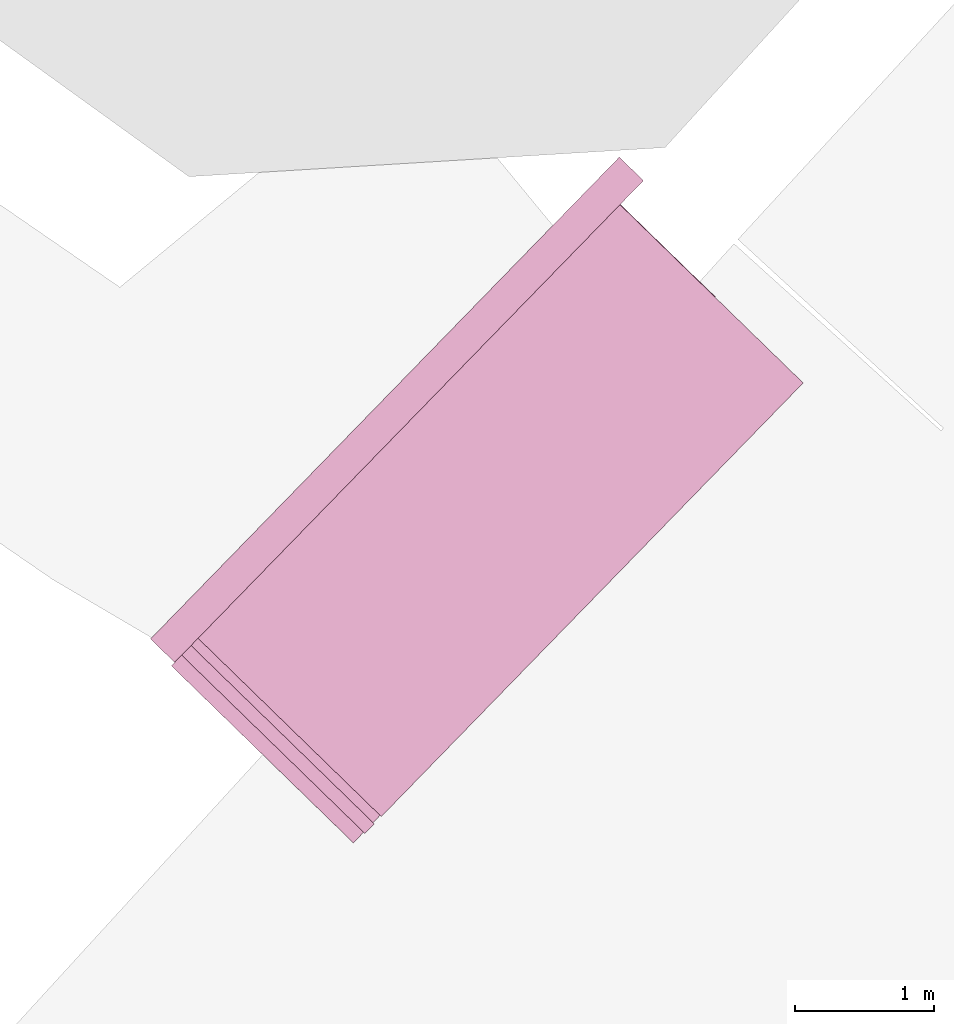
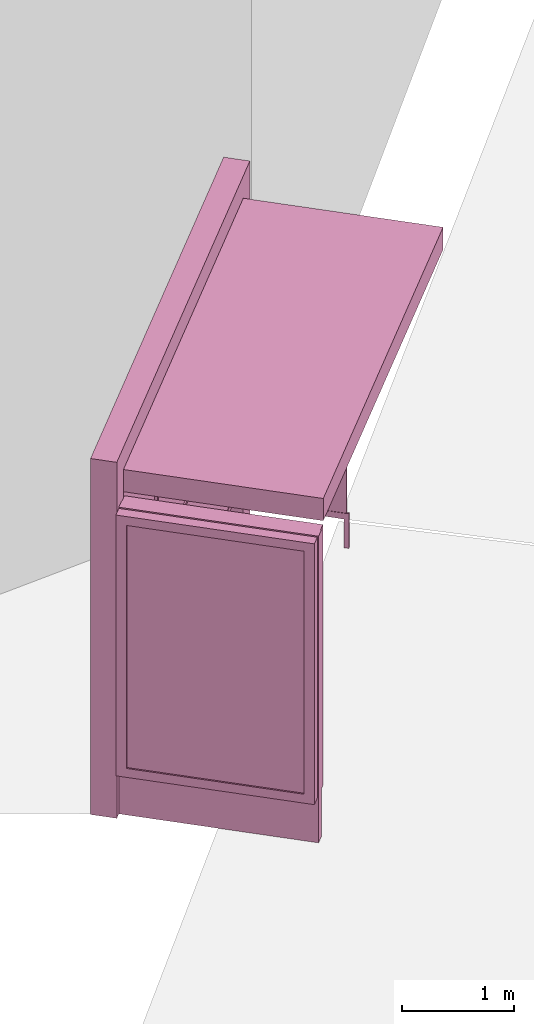
# One storey, part 16 of 200: 1 furnishing.
"""IFC4 building model written with IfcOpenShell, lengths in metres."""

from ifc_helpers import new_model, si_unit, origin_with_axes, place, context, subcontext, project, spatial, triangles, material, element, save


model = new_model("IFC4")

# Units and contexts
model_context = context("Model", 3, precision=1e-05, world=origin_with_axes())
body_context = subcontext(model_context, "Body", "Model", "MODEL_VIEW")
ifc_project = project(units=[si_unit("VOLUMEUNIT", "CUBIC_METRE"), si_unit("LENGTHUNIT", "METRE"), si_unit("AREAUNIT", "SQUARE_METRE")], contexts=[model_context])

# Site, building, storey
site_placement = place(None, origin_with_axes())
site = spatial("IfcSite", under=ifc_project, at=site_placement)
building_placement = place(site_placement, origin_with_axes())
building = spatial("IfcBuilding", under=site, at=building_placement, Name="Building")
storey_placement = place(building_placement, origin_with_axes())
storey = spatial("IfcBuildingStorey", under=building, at=storey_placement, Name="Ground")

# Furnishing
ifc_material = material(Name="busStop")
furnishing_placement = place(storey_placement, origin_with_axes())
element("IfcFurnishingElement", 1, at=furnishing_placement, inside=storey, material=ifc_material, Name="cw_instances_busStop_30", context=body_context, shape_type="Tessellation", body=[
    triangles([(510.81362514484823, -674.8429660042176, 3.3826375611235573), (512.3524115646801, -670.2866190238973, 3.3826375611235573), (509.3267755446598, -673.3962991293622, 3.3826375611235573), (513.8392614378605, -671.7332859177407, 3.3826375611235573), (510.81362521395226, -674.8429660714539, 3.6236783199298275), (512.3524116337842, -670.2866190911336, 3.6236783199298275), (513.8392615069646, -671.733285984977, 3.6236783199298275), (509.32677561376386, -673.3962991965985, 3.6236783199298275), (510.81362514484823, -674.8429660042176, 3.3826375611235573), (513.8392615069646, -671.733285984977, 3.6236783199298275), (513.8392614378605, -671.7332859177407, 3.3826375611235573), (510.81362521395226, -674.8429660714539, 3.6236783199298275), (513.8392614378605, -671.7332859177407, 3.3826375611235573), (512.3524116337842, -670.2866190911336, 3.6236783199298275), (512.3524115646801, -670.2866190238973, 3.3826375611235573), (513.8392615069646, -671.733285984977, 3.6236783199298275), (512.3524115646801, -670.2866190238973, 3.3826375611235573), (509.32677561376386, -673.3962991965985, 3.6236783199298275), (509.3267755446598, -673.3962991293622, 3.3826375611235573), (512.3524116337842, -670.2866190911336, 3.6236783199298275), (509.3267755446598, -673.3962991293622, 3.3826375611235573), (510.81362521395226, -674.8429660714539, 3.6236783199298275), (510.81362514484823, -674.8429660042176, 3.3826375611235573), (509.32677561376386, -673.3962991965985, 3.6236783199298275), (509.499535902697, -673.5643902885336, 3.864718677001767), (509.15868490999424, -673.5690596165804, 3.864718677001767), (509.3267758786626, -673.3962994543378, 3.864718677001767), (509.3314449340287, -673.737150450776, 3.864718677001767), (509.499535902697, -673.5643902885336, 3.6236783199298275), (509.3314449340287, -673.737150450776, 3.864718677001767), (509.499535902697, -673.5643902885336, 3.864718677001767), (509.3314449340287, -673.737150450776, 3.6236783199298275), (512.6932628954323, -670.2819503162302, 3.6236783199298275), (512.5205027331898, -670.1138593475619, 3.864718677001767), (512.5205027331898, -670.1138593475619, 3.6236783199298275), (512.6932628954323, -670.2819503162302, 3.864718677001767), (512.3524119102002, -670.2866193600789, 3.6236783199298275), (512.5205027331898, -670.1138593475619, 3.864718677001767), (512.3524119102002, -670.2866193600789, 3.864718677001767), (512.5205027331898, -670.1138593475619, 3.6236783199298275), (509.15868478330356, -673.5690594933137, 3.6236783199298275), (509.3314449340287, -673.737150450776, 3.864718677001767), (509.3314449340287, -673.737150450776, 3.6236783199298275), (509.15868490999424, -673.5690596165804, 3.864718677001767), (512.5251719342347, -670.4547101942746, 3.864718677001767), (512.3524119102002, -670.2866193600789, 3.864718677001767), (512.5251719342347, -670.4547101942746, 3.6236783199298275), (512.5251719342347, -670.4547101942746, 3.864718677001767), (509.15868478330356, -673.5690594933137, 3.6236783199298275), (509.3267758786626, -673.3962994543378, 3.864718677001767), (509.15868490999424, -673.5690596165804, 3.864718677001767), (509.3267758786626, -673.3962994543378, 3.6236783199298275), (512.6932628954323, -670.2819503162302, 3.864718677001767), (512.5205027331898, -670.1138593475619, 3.864718677001767), (512.6932628954323, -670.2819503162302, 3.6236783199298275), (512.6932628954323, -670.2819503162302, 3.864718677001767), (509.1586841613674, -673.5690588881866, 9.480930192426488e-07), (509.3314441162978, -673.7371496551459, 8.998848996201414e-07), (509.32677513003574, -673.3962987259441, 9.480930192426488e-07), (509.1586841613674, -673.5690588881866, 9.480930192426488e-07), (509.3267758786626, -673.3962994543378, 3.6236783199298275), (509.49953521165685, -673.5643896161702, 8.998848996201414e-07), (509.499535902697, -673.5643902885336, 3.6236783199298275), (509.32677513003574, -673.3962987259441, 9.480930192426488e-07), (509.3314441162978, -673.7371496551459, 8.998848996201414e-07), (509.49953521165685, -673.5643896161702, 8.998848996201414e-07), (512.6932610016087, -670.2819506035411, 8.998848996201414e-07), (512.520501984563, -670.1138586191681, 9.480930192426488e-07), (512.525170167413, -670.4547106275755, 8.998848996201414e-07), (512.6932610016087, -670.2819506035411, 8.998848996201414e-07), (512.5251719342347, -670.4547101942746, 3.6236783199298275), (512.3524100857919, -670.2866197373495, 9.480930192426488e-07), (512.3524119102002, -670.2866193600789, 3.6236783199298275), (512.525170167413, -670.4547106275755, 8.998848996201414e-07), (512.520501984563, -670.1138586191681, 9.480930192426488e-07), (512.3524100857919, -670.2866197373495, 9.480930192426488e-07), (513.2068975161724, -671.1183603637644, 0.3459945917589383), (512.4570075507662, -670.3887376947206, 3.3826375611235573), (512.45700692883, -670.3887370895935, 0.34599476852204364), (513.2068980805219, -671.1183609128612, 3.3826375611235573), (512.4458008829289, -670.4002544145474, 0.34599476852204364), (513.1956920346207, -671.1298782378152, 3.3826375611235573), (513.1956914702713, -671.1298776887184, 0.3459945917589383), (512.445801504865, -670.4002550196745, 3.3826375611235573), (513.1956914702713, -671.1298776887184, 0.3459945917589383), (513.2068980805219, -671.1183609128612, 3.3826375611235573), (513.2068975161724, -671.1183603637644, 0.3459945917589383), (513.1956920346207, -671.1298782378152, 3.3826375611235573), (512.4429993014157, -670.4031338177692, 0.313856054245785), (513.2096989286608, -671.1154810651325, 0.3138558614133065), (512.4598083758705, -670.3858578245797, 0.313856054245785), (513.1928898542061, -671.132757058322, 0.3138558614133065), (512.4429993014157, -670.4031338177692, 0.37813349886767544), (513.2096989401782, -671.1154810763385, 0.37813330603519696), (513.1928898657235, -671.1327570695281, 0.37813330603519696), (512.4598083758705, -670.3858578245797, 0.37813349886767544), (512.4429993014157, -670.4031338177692, 0.313856054245785), (513.1928898657235, -671.1327570695281, 0.37813330603519696), (513.1928898542061, -671.132757058322, 0.3138558614133065), (512.4429993014157, -670.4031338177692, 0.37813349886767544), (513.2096989286608, -671.1154810651325, 0.3138558614133065), (512.4598083758705, -670.3858578245797, 0.37813349886767544), (512.4598083758705, -670.3858578245797, 0.313856054245785), (513.2096989401782, -671.1154810763385, 0.37813330603519696), (513.2096989401782, -671.1154810763385, 0.37813330603519696), (513.1928898542061, -671.132757058322, 0.3138558614133065), (513.1928898657235, -671.1327570695281, 0.37813330603519696), (513.2096989286608, -671.1154810651325, 0.3138558614133065), (513.2113513548538, -671.145513642766, 0.37813330603519696), (513.1912363441384, -671.1027258251041, 0.37813330603519696), (513.2229552269883, -671.13358744085, 0.37813330603519696), (513.1796324720038, -671.1146520270202, 0.37813330603519696), (513.2113511705764, -671.1455134634691, 1.446243588675227e-07), (513.2229552269883, -671.13358744085, 0.37813330603519696), (513.222955042711, -671.1335872615531, 1.446243588675227e-07), (513.2113513548538, -671.145513642766, 0.37813330603519696), (513.222955042711, -671.1335872615531, 1.446243588675227e-07), (513.1912363441384, -671.1027258251041, 0.37813330603519696), (513.191236263517, -671.1027257466617, 1.6069373207502523e-07), (513.2229552269883, -671.13358744085, 0.37813330603519696), (513.191236263517, -671.1027257466617, 1.6069373207502523e-07), (513.1796324720038, -671.1146520270202, 0.37813330603519696), (513.1796323913825, -671.1146519485777, 1.6069373207502523e-07), (513.1912363441384, -671.1027258251041, 0.37813330603519696), (513.1796323913825, -671.1146519485777, 1.6069373207502523e-07), (513.2113513548538, -671.145513642766, 0.37813330603519696), (513.2113511705764, -671.1455134634691, 1.446243588675227e-07), (513.1796324720038, -671.1146520270202, 0.37813330603519696), (510.4578625741271, -672.673845460023, 1.1248564780513874), (511.46849650632066, -671.4151122446012, 1.1248565744676267), (511.57846863036565, -671.5221121490774, 1.1248564780513874), (510.34789058829017, -672.5668456900196, 1.1248565744676267), (511.57846849215764, -671.5221120146048, 4.981505694325782e-07), (510.4578625741271, -672.673845460023, 0.964162810253855), (511.57846863036565, -671.5221121490774, 0.964162810253855), (510.457862332263, -672.6738452246958, 4.981505694325782e-07), (511.4684962299046, -671.4151119756559, 5.302893158475833e-07), (511.57846863036565, -671.5221121490774, 0.964162810253855), (511.46849650632066, -671.4151122446012, 0.9641629066700942), (511.57846849215764, -671.5221120146048, 4.981505694325782e-07), (510.3478903118741, -672.5668454210742, 5.302893158475833e-07), (511.46849650632066, -671.4151122446012, 0.9641629066700942), (510.34789058829017, -672.5668456900196, 0.9641629066700942), (511.4684962299046, -671.4151119756559, 5.302893158475833e-07), (510.457862332263, -672.6738452246958, 4.981505694325782e-07), (510.34789058829017, -672.5668456900196, 0.9641629066700942), (510.4578625741271, -672.673845460023, 0.964162810253855), (510.3478903118741, -672.5668454210742, 5.302893158475833e-07), (512.0391620431473, -671.9703543885406, 1.124856381635148), (510.91855604449535, -673.1220877555165, 0.9641627138376155), (510.91855606753, -673.1220877779286, 1.124856381635148), (512.0391620316299, -671.9703543773346, 0.9641627138376155), (511.46849650632066, -671.4151122446012, 1.1248565744676267), (511.57846863036565, -671.5221121490774, 1.1248564780513874), (510.34789058829017, -672.5668456900196, 1.1248565744676267), (511.46849650632066, -671.4151122446012, 1.1248565744676267), (510.4578625741271, -672.673845460023, 1.1248564780513874), (510.34789058829017, -672.5668456900196, 1.1248565744676267), (510.91855606753, -673.1220877779286, 1.124856381635148), (512.0391620431473, -671.9703543885406, 1.124856381635148), (510.91855604449535, -673.1220877555165, 0.9641627138376155), (510.91855606753, -673.1220877779286, 1.124856381635148), (512.0391620431473, -671.9703543885406, 1.124856381635148), (512.0391620316299, -671.9703543773346, 0.9641627138376155), (509.3399022262601, -673.603948172838, 0.34599476852204364), (512.546986485765, -670.307781119873, 3.503157940526693), (512.5469858062422, -670.3077804587156, 0.34599476852204364), (509.3399027099882, -673.6039486434925, 3.503157940526693), (512.535468469771, -670.2965744016084, 0.34599476852204364), (509.3283853850343, -673.5927425975914, 3.503157940526693), (509.32838490130615, -673.592742126937, 0.34599476852204364), (512.5354691608111, -670.2965750739718, 3.503157940526693), (509.38815324049347, -673.8171253333096, 0.5810001600002933), (510.5552505307453, -674.9526794535547, 3.2193552137185355), (510.5552501161212, -674.9526790501366, 0.5809998707515756), (509.38815367815226, -673.8171257591398, 3.2193552137185355), (509.30784317576473, -673.7614063156204, 0.4845839046859049), (510.5440440702201, -674.9641963750905, 0.5809998707515756), (510.6131469553683, -675.0314337446442, 0.48458358329844076), (509.37694719459233, -673.8286426582636, 0.5810001600002933), (510.5440444848442, -674.9641967785086, 3.2193552137185355), (510.6131486418799, -675.0314332556244, 3.3157713565473115), (509.37694763225113, -673.8286430840938, 3.2193552137185355), (509.3078436479755, -673.7614067750687, 3.3157713565473115), (509.37694719459233, -673.8286426582636, 0.5810001600002933), (510.5552501161212, -674.9526790501366, 0.5809998707515756), (510.5440440702201, -674.9641963750905, 0.5809998707515756), (509.38815324049347, -673.8171253333096, 0.5810001600002933), (510.5440440702201, -674.9641963750905, 0.5809998707515756), (510.5552505307453, -674.9526794535547, 3.2193552137185355), (510.5440444848442, -674.9641967785086, 3.2193552137185355), (510.5552501161212, -674.9526790501366, 0.5809998707515756), (510.5440444848442, -674.9641967785086, 3.2193552137185355), (509.38815367815226, -673.8171257591398, 3.2193552137185355), (509.37694763225113, -673.8286430840938, 3.2193552137185355), (510.5552505307453, -674.9526794535547, 3.2193552137185355), (509.37694763225113, -673.8286430840938, 3.2193552137185355), (509.38815324049347, -673.8171253333096, 0.5810001600002933), (509.37694719459233, -673.8286426582636, 0.5810001600002933), (509.38815367815226, -673.8171257591398, 3.2193552137185355), (510.8284416298224, -674.8101599069057, 3.3157713565473115), (509.3078436479755, -673.7614067750687, 3.3157713565473115), (509.5231368432301, -673.540133628059, 3.3157713565473115), (510.6131486418799, -675.0314332556244, 3.3157713565473115), (510.8284410078862, -674.8101593017785, 0.48458358329844076), (510.6131486418799, -675.0314332556244, 3.3157713565473115), (510.8284416298224, -674.8101599069057, 3.3157713565473115), (510.6131469553683, -675.0314337446442, 0.48458358329844076), (509.30784317576473, -673.7614063156204, 0.4845839046859049), (509.5231368432301, -673.540133628059, 3.3157713565473115), (509.3078436479755, -673.7614067750687, 3.3157713565473115), (509.52313629039793, -673.5401330901683, 0.4845839046859049), (509.5810342402898, -673.6188867353533, 0.5810001600002933), (510.7481314268856, -674.7544407547438, 3.2193552137185355), (509.5810348161566, -673.6188872956561, 3.2193552137185355), (510.74813101226147, -674.7544403513258, 0.5809998707515756), (509.52313629039793, -673.5401330901683, 0.4845839046859049), (510.7593370581626, -674.7429230263718, 0.5809998707515756), (509.59224028619093, -673.6073694103993, 0.5810001600002933), (510.8284410078862, -674.8101593017785, 0.48458358329844076), (510.75933747278674, -674.7429234297898, 3.2193552137185355), (510.8284416298224, -674.8101599069057, 3.3157713565473115), (509.59224086205774, -673.6073699707022, 3.2193552137185355), (509.5231368432301, -673.540133628059, 3.3157713565473115), (509.59224028619093, -673.6073694103993, 0.5810001600002933), (510.74813101226147, -674.7544403513258, 0.5809998707515756), (509.5810342402898, -673.6188867353533, 0.5810001600002933), (510.7593370581626, -674.7429230263718, 0.5809998707515756), (510.7593370581626, -674.7429230263718, 0.5809998707515756), (510.7481314268856, -674.7544407547438, 3.2193552137185355), (510.74813101226147, -674.7544403513258, 0.5809998707515756), (510.75933747278674, -674.7429234297898, 3.2193552137185355), (510.75933747278674, -674.7429234297898, 3.2193552137185355), (509.5810348161566, -673.6188872956561, 3.2193552137185355), (510.7481314268856, -674.7544407547438, 3.2193552137185355), (509.59224086205774, -673.6073699707022, 3.2193552137185355), (509.59224086205774, -673.6073699707022, 3.2193552137185355), (509.5810342402898, -673.6188867353533, 0.5810001600002933), (509.5810348161566, -673.6188872956561, 3.2193552137185355), (509.59224028619093, -673.6073694103993, 0.5810001600002933), (510.6959627218588, -674.9638968278457, 3.3287619342644956), (509.44910827965015, -673.6162181258476, 3.3287619342644956), (510.76319793269016, -674.894793972269, 3.3287619342644956), (509.3818720042434, -673.6853220755712, 3.3287619342644956), (510.69596103908253, -674.9638975895463, 0.0), (510.76319793269016, -674.894793972269, 3.3287619342644956), (510.763197448962, -674.8947935016146, 0.0), (510.6959627218588, -674.9638968278457, 3.3287619342644956), (510.763197448962, -674.8947935016146, 0.0), (509.44910827965015, -673.6162181258476, 3.3287619342644956), (509.44910773833533, -673.616217599163, 5.142199426400808e-07), (510.76319793269016, -674.894793972269, 3.3287619342644956), (509.44910773833533, -673.616217599163, 5.142199426400808e-07), (509.3818720042434, -673.6853220755712, 3.3287619342644956), (509.3818714629286, -673.6853215488866, 5.142199426400808e-07), (509.44910827965015, -673.6162181258476, 3.3287619342644956), (509.3818714629286, -673.6853215488866, 5.142199426400808e-07), (510.6959627218588, -674.9638968278457, 3.3287619342644956), (510.69596103908253, -674.9638975895463, 0.0), (509.3818720042434, -673.6853220755712, 3.3287619342644956), (509.34278156037794, -673.6067496871149, 0.313856054245785), (512.4632023266827, -670.3650869924458, 0.313856054245785), (509.32550549808434, -673.5899405454238, 0.313856054245785), (512.4804783083549, -670.3818960556945, 0.313856054245785), (509.34278156037794, -673.6067496871149, 0.37813349886767544), (512.4632023266827, -670.3650869924458, 0.37813349886767544), (512.4804783083549, -670.3818960556945, 0.37813349886767544), (509.32550549808434, -673.5899405454238, 0.37813349886767544), (509.34278156037794, -673.6067496871149, 0.313856054245785), (512.4804783083549, -670.3818960556945, 0.37813349886767544), (512.4804783083549, -670.3818960556945, 0.313856054245785), (509.34278156037794, -673.6067496871149, 0.37813349886767544), (512.4632023266827, -670.3650869924458, 0.313856054245785), (509.32550549808434, -673.5899405454238, 0.37813349886767544), (509.32550549808434, -673.5899405454238, 0.313856054245785), (512.4632023266827, -670.3650869924458, 0.37813349886767544), (510.46060386051613, -672.4523067132734, 1.5290613779533648), (511.3570889240251, -671.5309202547086, 2.8146110577904615), (510.4606041369322, -672.4523069822188, 2.8146110577904615), (511.35708864760903, -671.5309199857633, 1.5290613779533648), (510.49269703283284, -672.4386914257938, 1.5612002850621018), (511.3443578339836, -671.5633743249426, 2.7824723435142027), (511.34435743087687, -671.5633739327307, 1.5612002850621018), (510.4926971710409, -672.4386915602664, 2.7824723435142027), (510.46060386051613, -672.4523067132734, 1.5290613779533648), (511.37828701945926, -671.5515454286445, 1.5290613779533648), (511.35708864760903, -671.5309199857633, 1.5290613779533648), (510.48180209415835, -672.472932021682, 1.5290613779533648), (511.35708864760903, -671.5309199857633, 1.5290613779533648), (511.37828714614994, -671.5515455519112, 2.8146110577904615), (511.3570889240251, -671.5309202547086, 2.8146110577904615), (511.37828701945926, -671.5515454286445, 1.5290613779533648), (511.3570889240251, -671.5309202547086, 2.8146110577904615), (510.4818023705744, -672.4729322906275, 2.8146110577904615), (510.4606041369322, -672.4523069822188, 2.8146110577904615), (511.37828714614994, -671.5515455519112, 2.8146110577904615), (510.4606041369322, -672.4523069822188, 2.8146110577904615), (510.48180209415835, -672.472932021682, 1.5290613779533648), (510.46060386051613, -672.4523067132734, 1.5290613779533648), (510.4818023705744, -672.4729322906275, 2.8146110577904615), (511.61879760594996, -671.261941334135, 1.5290613779533648), (512.1791010813777, -670.6860749793581, 2.8146110577904615), (511.61879808781043, -671.2619416684491, 2.8146110577904615), (512.1791008049616, -670.6860747104128, 1.5290613779533648), (511.65089074091316, -671.2483258085266, 1.5612002850621018), (512.1663698176424, -670.7185288133311, 2.7824723435142027), (512.1663696103303, -670.7185286116221, 1.5612002850621018), (511.65089114401997, -671.2483262007387, 2.7824723435142027), (511.61879760594996, -671.261941334135, 1.5290613779533648), (512.2002990270865, -670.7067000076154, 1.5290613779533648), (512.1791008049616, -670.6860747104128, 1.5290613779533648), (511.6399959778002, -671.2825667770163, 1.5290613779533648), (512.1791008049616, -670.6860747104128, 1.5290613779533648), (512.2002993035026, -670.7067002765607, 2.8146110577904615), (512.1791010813777, -670.6860749793581, 2.8146110577904615), (512.2002990270865, -670.7067000076154, 1.5290613779533648), (512.1791010813777, -670.6860749793581, 2.8146110577904615), (511.63999630993527, -671.2825669656517, 2.8146110577904615), (511.61879808781043, -671.2619416684491, 2.8146110577904615), (512.2002993035026, -670.7067002765607, 2.8146110577904615), (511.61879808781043, -671.2619416684491, 2.8146110577904615), (511.6399959778002, -671.2825667770163, 1.5290613779533648), (511.61879760594996, -671.261941334135, 1.5290613779533648), (511.63999630993527, -671.2825669656517, 2.8146110577904615), (510.48180209415835, -672.472932021682, 1.5290613779533648), (511.3558748249348, -671.5745800458681, 1.5612002850621018), (511.37828701945926, -671.5515454286445, 1.5290613779533648), (510.5042142195788, -672.4498973372222, 1.5612002850621018), (511.3558750207295, -671.574580236371, 2.7824723435142027), (511.37828714614994, -671.5515455519112, 2.8146110577904615), (510.50421449599486, -672.4498976061675, 2.7824723435142027), (510.4818023705744, -672.4729322906275, 2.8146110577904615), (511.6399959778002, -671.2825667770163, 1.5290613779533648), (512.1778869352843, -670.7297346575232, 1.5612002850621018), (512.2002990270865, -670.7067000076154, 1.5290613779533648), (511.6624082040752, -671.2595319889004, 1.5612002850621018), (512.1778872117003, -670.7297349264686, 2.7824723435142027), (512.2002993035026, -670.7067002765607, 2.8146110577904615), (511.66240846897387, -671.2595322466398, 2.7824723435142027), (511.63999630993527, -671.2825669656517, 2.8146110577904615), (510.5042142195788, -672.4498973372222, 1.5612002850621018), (511.34435743087687, -671.5633739327307, 1.5612002850621018), (511.3558748249348, -671.5745800458681, 1.5612002850621018), (510.49269703283284, -672.4386914257938, 1.5612002850621018), (511.3558748249348, -671.5745800458681, 1.5612002850621018), (511.3443578339836, -671.5633743249426, 2.7824723435142027), (511.3558750207295, -671.574580236371, 2.7824723435142027), (511.34435743087687, -671.5633739327307, 1.5612002850621018), (511.3558750207295, -671.574580236371, 2.7824723435142027), (510.4926971710409, -672.4386915602664, 2.7824723435142027), (510.50421449599486, -672.4498976061675, 2.7824723435142027), (511.3443578339836, -671.5633743249426, 2.7824723435142027), (510.50421449599486, -672.4498976061675, 2.7824723435142027), (510.49269703283284, -672.4386914257938, 1.5612002850621018), (510.5042142195788, -672.4498973372222, 1.5612002850621018), (510.4926971710409, -672.4386915602664, 2.7824723435142027), (511.6624082040752, -671.2595319889004, 1.5612002850621018), (512.1663696103303, -670.7185286116221, 1.5612002850621018), (512.1778869352843, -670.7297346575232, 1.5612002850621018), (511.65089074091316, -671.2483258085266, 1.5612002850621018), (512.1778869352843, -670.7297346575232, 1.5612002850621018), (512.1663698176424, -670.7185288133311, 2.7824723435142027), (512.1778872117003, -670.7297349264686, 2.7824723435142027), (512.1663696103303, -670.7185286116221, 1.5612002850621018), (512.1778872117003, -670.7297349264686, 2.7824723435142027), (511.65089114401997, -671.2483262007387, 2.7824723435142027), (511.66240846897387, -671.2595322466398, 2.7824723435142027), (512.1663698176424, -670.7185288133311, 2.7824723435142027), (511.66240846897387, -671.2595322466398, 2.7824723435142027), (511.65089074091316, -671.2483258085266, 1.5612002850621018), (511.6624082040752, -671.2595319889004, 1.5612002850621018), (511.65089114401997, -671.2483262007387, 2.7824723435142027)], [[1, 3, 2], [2, 4, 1], [5, 7, 6], [6, 8, 5], [9, 11, 10], [10, 12, 9], [13, 15, 14], [14, 16, 13], [17, 19, 18], [18, 20, 17], [21, 23, 22], [22, 24, 21], [25, 27, 26], [26, 28, 25], [29, 31, 30], [30, 32, 29], [33, 35, 34], [34, 36, 33], [37, 39, 38], [38, 40, 37], [41, 43, 42], [42, 44, 41], [45, 46, 27], [27, 25, 45], [47, 48, 31], [31, 29, 47], [49, 51, 50], [50, 52, 49], [52, 50, 39], [39, 37, 52], [53, 54, 46], [46, 45, 53], [55, 56, 48], [48, 47, 55], [43, 41, 57], [57, 58, 43], [49, 52, 59], [59, 60, 49], [61, 63, 62], [62, 64, 61], [29, 32, 65], [65, 66, 29], [35, 33, 67], [67, 68, 35], [55, 47, 69], [69, 70, 55], [71, 73, 72], [72, 74, 71], [37, 40, 75], [75, 76, 37], [77, 79, 78], [78, 80, 77], [81, 83, 82], [82, 84, 81], [85, 87, 86], [86, 88, 85], [89, 91, 90], [90, 92, 89], [93, 95, 94], [94, 96, 93], [97, 99, 98], [98, 100, 97], [101, 103, 102], [102, 104, 101], [105, 107, 106], [106, 108, 105], [109, 111, 110], [110, 112, 109], [113, 115, 114], [114, 116, 113], [117, 119, 118], [118, 120, 117], [121, 123, 122], [122, 124, 121], [125, 127, 126], [126, 128, 125], [129, 131, 130], [130, 132, 129], [133, 135, 134], [134, 136, 133], [137, 139, 138], [138, 140, 137], [141, 143, 142], [142, 144, 141], [145, 147, 146], [146, 148, 145], [149, 151, 150], [150, 152, 149], [153, 154, 138], [138, 139, 153], [155, 156, 142], [142, 143, 155], [157, 158, 146], [146, 147, 157], [131, 129, 159], [159, 160, 131], [157, 147, 161], [161, 162, 157], [138, 154, 163], [163, 164, 138], [165, 167, 166], [166, 168, 165], [169, 171, 170], [170, 172, 169], [173, 175, 174], [174, 176, 173], [177, 179, 178], [178, 180, 177], [179, 182, 181], [181, 178, 179], [182, 184, 183], [183, 181, 182], [184, 177, 180], [180, 183, 184], [185, 187, 186], [186, 188, 185], [189, 191, 190], [190, 192, 189], [193, 195, 194], [194, 196, 193], [197, 199, 198], [198, 200, 197], [201, 203, 202], [202, 204, 201], [205, 207, 206], [206, 208, 205], [209, 211, 210], [210, 212, 209], [213, 215, 214], [214, 216, 213], [217, 219, 218], [218, 220, 217], [220, 218, 221], [221, 222, 220], [222, 221, 223], [223, 224, 222], [224, 223, 219], [219, 217, 224], [225, 227, 226], [226, 228, 225], [229, 231, 230], [230, 232, 229], [233, 235, 234], [234, 236, 233], [237, 239, 238], [238, 240, 237], [241, 243, 242], [242, 244, 241], [245, 247, 246], [246, 248, 245], [249, 251, 250], [250, 252, 249], [253, 255, 254], [254, 256, 253], [257, 259, 258], [258, 260, 257], [261, 263, 262], [262, 264, 261], [265, 267, 266], [266, 268, 265], [269, 271, 270], [270, 272, 269], [273, 275, 274], [274, 276, 273], [277, 279, 278], [278, 280, 277], [281, 283, 282], [282, 284, 281], [285, 287, 286], [286, 288, 285], [289, 291, 290], [290, 292, 289], [293, 295, 294], [294, 296, 293], [297, 299, 298], [298, 300, 297], [301, 303, 302], [302, 304, 301], [305, 307, 306], [306, 308, 305], [309, 311, 310], [310, 312, 309], [313, 315, 314], [314, 316, 313], [317, 319, 318], [318, 320, 317], [321, 323, 322], [322, 324, 321], [325, 327, 326], [326, 328, 325], [327, 330, 329], [329, 326, 327], [330, 332, 331], [331, 329, 330], [332, 325, 328], [328, 331, 332], [333, 335, 334], [334, 336, 333], [335, 338, 337], [337, 334, 335], [338, 340, 339], [339, 337, 338], [340, 333, 336], [336, 339, 340], [341, 343, 342], [342, 344, 341], [345, 347, 346], [346, 348, 345], [349, 351, 350], [350, 352, 349], [353, 355, 354], [354, 356, 353], [357, 359, 358], [358, 360, 357], [361, 363, 362], [362, 364, 361], [365, 367, 366], [366, 368, 365], [369, 371, 370], [370, 372, 369]], closed=True),
])

save(model, "model.ifc")
